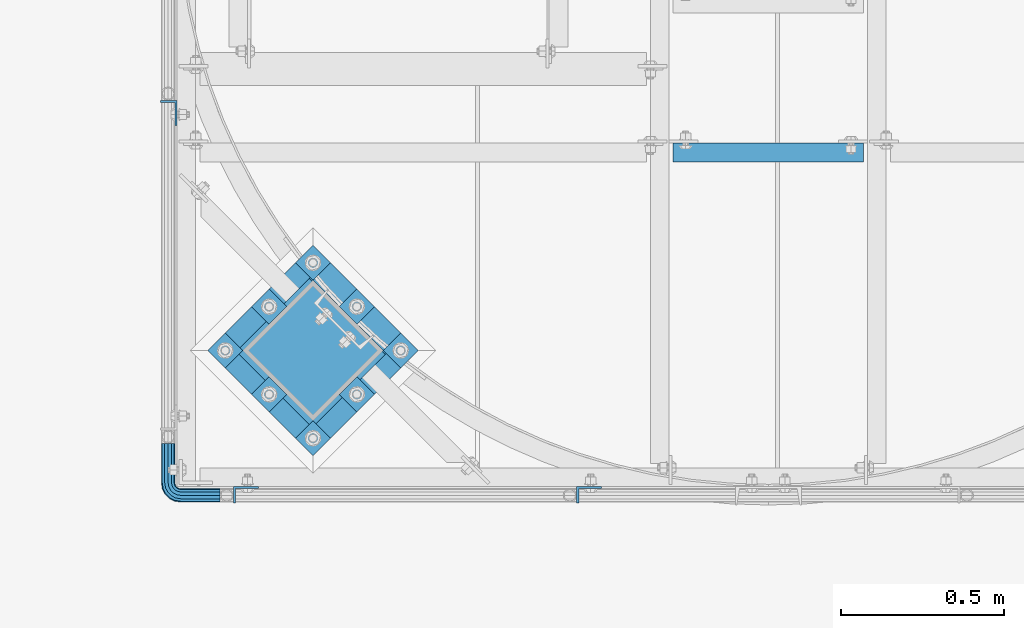
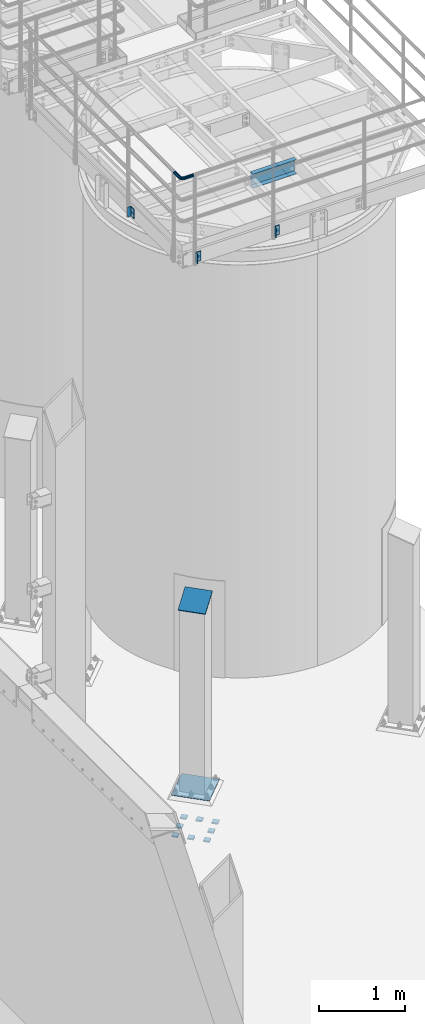
# One storey, part 1100 of 1876: 14 beams, 1 member, 5 elements without a shape of their own.
"""IFC2X3 building model written with IfcOpenShell, lengths in millimetres."""

from ifc_helpers import new_model, si_unit, frame, origin_with_axes, place, context, subcontext, project, spatial, faceted_brep, material, type_object, element, aggregate, save


model = new_model("IFC2X3")

# Units and contexts
model_context = context("Model", 3, precision=1e-05, world=origin_with_axes())
body_context = subcontext(model_context, "Body", "Model", "MODEL_VIEW")
ifc_project = project(units=[si_unit("LENGTHUNIT", "METRE", prefix="MILLI"), si_unit("AREAUNIT", "SQUARE_METRE"), si_unit("VOLUMEUNIT", "CUBIC_METRE"), si_unit("MASSUNIT", "GRAM", prefix="KILO"), si_unit("TIMEUNIT", "SECOND"), si_unit("PLANEANGLEUNIT", "RADIAN"), si_unit("SOLIDANGLEUNIT", "STERADIAN"), si_unit("THERMODYNAMICTEMPERATUREUNIT", "DEGREE_CELSIUS"), si_unit("LUMINOUSINTENSITYUNIT", "LUMEN")], contexts=[model_context])

# Site, building, storey
site_placement = place(None, origin_with_axes())
site = spatial("IfcSite", under=ifc_project, at=site_placement, CompositionType="ELEMENT")
building_placement = place(site_placement, origin_with_axes())
building = spatial("IfcBuilding", under=site, at=building_placement, Name="Undefined", CompositionType="ELEMENT")
storey_placement = place(building_placement, origin_with_axes())
storey = spatial("IfcBuildingStorey", under=building, at=storey_placement, Name="Undefined", CompositionType="ELEMENT", Elevation=0.0)

# Assembly, beam
assembly_1_placement = place(storey_placement, origin_with_axes())
assembly_1 = element("IfcElementAssembly", 1, at=assembly_1_placement, inside=storey, Name="HANDRAIL", AssemblyPlace="NOTDEFINED", PredefinedType="RIGID_FRAME")
ifc_material_1 = material()
beam_type_1 = type_object("IfcBeamType", Name="PIPE1-1/4STD", PredefinedType="NOTDEFINED")
beam_1_placement = place(assembly_1_placement, frame((3338.06943150122, -15273.6987792969, 9090.025), z_axis=(0.0, 0.0, -1.0), x_axis=(0.0, -1.0, 0.0)))
beam_1 = element("IfcBeam", 2, at=beam_1_placement, type_object=beam_type_1, material=ifc_material_1, Name="HANDRAIL", ObjectType="PIPE1-1/4STD", context=body_context, shape_type="Brep", body=[
    faceted_brep([(9.09494701772928e-13, -21.0820000000003, 0.0), (0.0, -18.2575475625836, -10.5409999999993), (120.697624206543, -18.2575475625817, -10.5410000000011), (120.697624206543, -21.0819999999985, -1.81898940354586e-12), (0.0, -10.5410000000002, -18.2575475625836), (120.697624206543, -10.5409999999983, -18.2575475625854), (-4.28826751885936e-09, 0.0, -21.0820000000003), (120.697624206542, 1.81898940354586e-12, -21.0820000000022), (0.0, 10.5410000000002, -18.2575475625836), (120.697624206542, 10.5410000000011, -18.2575475625854), (0.0, 18.2575475625836, -10.5409999999993), (120.697624206542, 18.2575475625845, -10.5410000000011), (9.09494701772928e-13, 21.0820000000003, 0.0), (120.697624206542, 21.0820000000012, -1.81898940354586e-12), (0.0, 18.2575475625836, 10.5409999999993), (120.697624206543, 18.2575475625845, 10.5409999999993), (0.0, 10.5410000000002, 18.2575475625836), (120.697624206543, 10.5410000000011, 18.2575475625817), (0.0, 0.0, 21.0820000000003), (120.697624206543, 1.81898940354586e-12, 21.0819999999985), (0.0, -10.5410000000002, 18.2575475625836), (120.697624206543, -10.5409999999983, 18.2575475625817), (0.0, -18.2575475625836, 10.5409999999993), (120.697624206543, -18.2575475625817, 10.5409999999993), (0.0, -17.5259999999998, 0.0), (0.0, -15.1779612267264, 8.76300000000083), (120.697624206543, -15.1779612267246, 8.76299999999901), (120.697624206543, -17.5259999999989, -1.81898940354586e-12), (0.0, -8.76299999999992, 15.1779612267255), (120.697624206543, -8.76299999999901, 15.1779612267255), (0.0, 0.0, 17.5259999999998), (120.697624206543, 1.81898940354586e-12, 17.525999999998), (0.0, 8.76299999999992, 15.1779612267255), (120.697624206543, 8.76300000000174, 15.1779612267255), (0.0, 15.1779612267264, 8.76300000000083), (120.697624206543, 15.1779612267273, 8.76299999999901), (0.0, 17.5259999999998, 0.0), (120.697624206542, 17.5260000000017, -1.81898940354586e-12), (0.0, 15.1779612267264, -8.76300000000083), (120.697624206542, 15.1779612267273, -8.76300000000083), (0.0, 8.76299999999992, -15.1779612267255), (120.697624206542, 8.76300000000174, -15.1779612267273), (0.0, 0.0, -17.5259999999998), (120.697624206542, 1.81898940354586e-12, -17.5260000000017), (0.0, -8.76299999999992, -15.1779612267255), (120.697624206543, -8.76299999999901, -15.1779612267273), (0.0, -15.1779612267264, -8.76300000000083), (120.697624206543, -15.1779612267246, -8.76300000000083), (125.956474945295, -21.9149201310065, -1.81898940354586e-12), (126.829278748261, -19.2287062354353, 10.5409999999993), (129.213823083002, -11.8898333927391, 18.2575475625817), (132.471171220709, -1.86474665447258, 21.0819999999985), (135.728519358417, 8.16034008379484, 18.2575475625817), (138.113063693158, 15.4992129264911, 10.5409999999993), (138.985867496124, 18.1854268220613, -1.81898940354586e-12), (138.113063693158, 15.4992129264911, -10.5410000000011), (135.728519358416, 8.16034008379393, -18.2575475625854), (132.471171220709, -1.86474665447258, -21.0820000000022), (129.213823083002, -11.8898333927391, -18.2575475625854), (126.829278748261, -19.2287062354353, -10.5410000000011), (137.887003064126, 14.803469850116, -1.81898940354586e-12), (137.161419179733, 12.5703522742797, 8.76299999999901), (135.179087142418, 6.46936159782126, 15.1779612267237), (132.471171220709, -1.86474665447258, 17.525999999998), (129.763255299001, -10.1988549067664, 15.1779612267255), (127.780923261686, -16.2998455832249, 8.76299999999901), (127.055339377293, -18.5329631590612, -1.81898940354586e-12), (127.780923261686, -16.2998455832249, -8.76300000000083), (129.763255299001, -10.1988549067664, -15.1779612267273), (132.471171220709, -1.86474665447258, -17.5260000000017), (135.179087142417, 6.46936159782126, -15.1779612267273), (137.161419179733, 12.5703522742797, -8.76300000000083), (149.288085766415, 1.2513959148082, 18.2575475625817), (153.823758622315, 7.49421403084034, 10.5409999999993), (143.092241421999, -7.27645222289721, 21.0819999999985), (136.896397077584, -15.8043003606035, 18.2575475625817), (132.360724221684, -22.0471184766357, 10.5409999999993), (130.700552733168, -24.3321484983098, -1.81898940354586e-12), (132.360724221683, -22.0471184766357, -10.5410000000011), (136.896397077584, -15.8043003606035, -18.2575475625854), (143.092241421999, -7.27645222289811, -21.0820000000022), (149.288085766414, 1.2513959148082, -18.2575475625854), (153.823758622315, 7.49421403084034, -10.5410000000011), (155.48393011083, 9.77924405251451, -1.81898940354586e-12), (152.013623190936, 5.00277634948725, -8.76300000000083), (153.393765753678, 6.90237962051742, -1.81898940354586e-12), (148.243003587838, -0.187036301190346, -15.1779612267273), (143.092241421999, -7.27645222289721, -17.5260000000017), (137.94147925616, -14.365868144605, -15.1779612267273), (134.170859653062, -19.5556807952826, -8.76300000000083), (132.79071709032, -21.4552840663118, -1.81898940354586e-12), (134.170859653062, -19.5556807952826, 8.76299999999901), (137.94147925616, -14.365868144605, 15.1779612267255), (143.092241421999, -7.27645222289721, 17.525999999998), (148.243003587839, -0.187036301190346, 15.1779612267237), (152.013623190936, 5.00277634948725, 8.76299999999901), (160.04901859547, -9.50953691424547, 18.2575475625817), (166.291836711502, -4.9738640583455, 10.5409999999993), (151.521170457764, -15.7053812586619, 21.0819999999985), (142.993322320059, -21.9012256030783, 18.2575475625817), (136.750504204027, -26.4368984589792, 10.5409999999993), (134.465474182353, -28.0970699474938, -1.81898940354586e-12), (136.750504204027, -26.4368984589792, -10.5410000000011), (142.993322320058, -21.9012256030783, -18.2575475625854), (151.521170457764, -15.7053812586619, -21.0820000000022), (160.04901859547, -9.50953691424638, -18.2575475625854), (166.291836711502, -4.9738640583455, -10.5410000000011), (168.576866733175, -3.31369256982998, -1.81898940354586e-12), (163.800399030148, -6.78399948972401, -8.76300000000083), (165.700002301178, -5.40385692698237, -1.81898940354586e-12), (158.610586379471, -10.5546190928226, -15.1779612267273), (151.521170457764, -15.7053812586619, -17.5260000000017), (144.431754536057, -20.8561434245021, -15.1779612267273), (139.24194188538, -24.6267630275997, -8.76300000000083), (137.34233861435, -26.0069055903414, -1.81898940354586e-12), (139.24194188538, -24.6267630275997, 8.76299999999901), (144.431754536057, -20.8561434245021, 15.1779612267255), (151.521170457764, -15.7053812586619, 17.525999999998), (158.610586379471, -10.5546190928217, 15.1779612267255), (163.800399030148, -6.78399948972401, 8.76299999999901), (166.957962764459, -23.0691033222502, 18.2575475625817), (174.296835607155, -20.6845589875093, 10.5409999999993), (156.932876026191, -26.3264514599568, 21.0819999999985), (146.907789287925, -29.5837995976626, 18.2575475625817), (139.568916445228, -31.9683439324035, 10.5409999999993), (136.882702549657, -32.8411477353693, -1.81898940354586e-12), (139.568916445228, -31.9683439324044, -10.5410000000011), (146.907789287924, -29.5837995976635, -18.2575475625854), (156.932876026191, -26.3264514599568, -21.0820000000022), (166.957962764458, -23.0691033222502, -18.2575475625854), (174.296835607155, -20.6845589875093, -10.5410000000011), (176.983049502726, -19.8117551845444, -1.81898940354586e-12), (171.367974954944, -21.6362035009342, -8.76300000000083), (173.60109253078, -20.9106196165412, -1.81898940354586e-12), (165.266984278486, -23.6185355382495, -15.1779612267273), (156.932876026191, -26.3264514599568, -17.5260000000017), (148.598767773897, -29.0343673816642, -15.1779612267273), (142.497777097438, -31.0166994189794, -8.76300000000083), (140.264659521603, -31.7422833033725, -1.81898940354586e-12), (142.497777097438, -31.0166994189794, 8.76299999999901), (148.598767773897, -29.0343673816642, 15.1779612267255), (156.932876026191, -26.3264514599568, 17.525999999998), (165.266984278486, -23.6185355382486, 15.1779612267255), (171.367974954945, -21.6362035009342, 8.76299999999901), (148.256622680664, -38.0999984741202, -18.2575475625854), (140.54007511808, -38.0999984741202, -10.5410000000011), (158.797622680664, -38.0999984741202, -21.0820000000003), (169.338622680664, -38.0999984741202, -18.2575475625854), (177.055170243248, -38.0999984741202, -10.5410000000011), (179.879622680664, -38.0999984741193, -1.81898940354586e-12), (177.055170243248, -38.0999984741193, 10.5409999999993), (169.338622680664, -38.0999984741193, 18.2575475625817), (158.797622680665, -38.0999984741193, 21.0819999999985), (148.256622680664, -38.0999984741193, 18.2575475625817), (140.540075118081, -38.0999984741193, 10.5409999999993), (137.715622680664, -38.0999984741193, -1.81898940354586e-12), (173.975583907391, -38.0999984741202, -8.76300000000083), (176.323622680664, -38.0999984741193, -1.81898940354586e-12), (167.560622680664, -38.0999984741202, -15.1779612267273), (158.797622680664, -38.0999984741202, -17.5260000000017), (150.034622680664, -38.0999984741202, -15.1779612267273), (143.619661453938, -38.0999984741202, -8.76300000000083), (141.271622680664, -38.0999984741193, -1.81898940354586e-12), (143.619661453938, -38.0999984741193, 8.76299999999901), (150.034622680665, -38.0999984741193, 15.1779612267255), (158.797622680665, -38.0999984741193, 17.525999999998), (167.560622680664, -38.0999984741193, 15.1779612267255), (173.975583907391, -38.0999984741193, 8.76299999999901), (140.54007511808, -158.750427246094, -10.5409999999993), (137.715622680664, -158.750427246094, 0.0), (148.256622680665, -158.750427246094, -18.2575475625836), (158.797622680664, -158.750427246094, -21.0820000000003), (169.338622680663, -158.750427246094, -18.2575475625836), (177.055170243248, -158.750427246094, -10.5409999999993), (179.879622680664, -158.750427246094, 0.0), (177.055170243248, -158.750427246094, 10.5409999999993), (169.338622680663, -158.750427246094, 18.2575475625836), (158.797622680664, -158.750427246094, 21.0820000000003), (148.256622680665, -158.750427246094, 18.2575475625836), (140.54007511808, -158.750427246094, 10.5409999999993), (143.619661453939, -158.750427246094, 8.76300000000083), (141.271622680664, -158.750427246094, 0.0), (150.034622680663, -158.750427246094, 15.1779612267255), (158.797622680664, -158.750427246094, 17.5259999999998), (167.560622680665, -158.750427246094, 15.1779612267255), (173.97558390739, -158.750427246094, 8.76300000000083), (176.323622680664, -158.750427246094, 0.0), (173.97558390739, -158.750427246094, -8.76300000000083), (167.560622680665, -158.750427246094, -15.1779612267255), (158.797622680664, -158.750427246094, -17.5259999999998), (150.034622680663, -158.750427246094, -15.1779612267255), (143.619661453939, -158.750427246094, -8.76300000000083)], [[[0, 1, 2, 3]], [[1, 4, 5, 2]], [[4, 6, 7, 5]], [[6, 8, 9, 7]], [[8, 10, 11, 9]], [[10, 12, 13, 11]], [[12, 14, 15, 13]], [[14, 16, 17, 15]], [[16, 18, 19, 17]], [[18, 20, 21, 19]], [[20, 22, 23, 21]], [[22, 0, 3, 23]], [[24, 25, 26, 27]], [[25, 28, 29, 26]], [[28, 30, 31, 29]], [[30, 32, 33, 31]], [[32, 34, 35, 33]], [[34, 36, 37, 35]], [[36, 38, 39, 37]], [[38, 40, 41, 39]], [[40, 42, 43, 41]], [[42, 44, 45, 43]], [[44, 46, 47, 45]], [[46, 24, 27, 47]], [[22, 20, 18, 16, 14, 12, 10, 8, 6, 4, 1, 0], [46, 44, 42, 40, 38, 36, 34, 32, 30, 28, 25, 24]], [[23, 3, 48, 49]], [[21, 23, 49, 50]], [[19, 21, 50, 51]], [[17, 19, 51, 52]], [[15, 17, 52, 53]], [[13, 15, 53, 54]], [[11, 13, 54, 55]], [[9, 11, 55, 56]], [[7, 9, 56, 57]], [[5, 7, 57, 58]], [[2, 5, 58, 59]], [[3, 2, 59, 48]], [[35, 37, 60, 61]], [[33, 35, 61, 62]], [[31, 33, 62, 63]], [[29, 31, 63, 64]], [[26, 29, 64, 65]], [[27, 26, 65, 66]], [[47, 27, 66, 67]], [[45, 47, 67, 68]], [[43, 45, 68, 69]], [[41, 43, 69, 70]], [[39, 41, 70, 71]], [[37, 39, 71, 60]], [[52, 72, 73, 53]], [[51, 74, 72, 52]], [[50, 75, 74, 51]], [[49, 76, 75, 50]], [[48, 77, 76, 49]], [[59, 78, 77, 48]], [[58, 79, 78, 59]], [[57, 80, 79, 58]], [[56, 81, 80, 57]], [[55, 82, 81, 56]], [[54, 83, 82, 55]], [[53, 73, 83, 54]], [[71, 84, 85, 60]], [[70, 86, 84, 71]], [[69, 87, 86, 70]], [[68, 88, 87, 69]], [[67, 89, 88, 68]], [[66, 90, 89, 67]], [[65, 91, 90, 66]], [[64, 92, 91, 65]], [[63, 93, 92, 64]], [[62, 94, 93, 63]], [[61, 95, 94, 62]], [[60, 85, 95, 61]], [[72, 96, 97, 73]], [[74, 98, 96, 72]], [[75, 99, 98, 74]], [[76, 100, 99, 75]], [[77, 101, 100, 76]], [[78, 102, 101, 77]], [[79, 103, 102, 78]], [[80, 104, 103, 79]], [[81, 105, 104, 80]], [[82, 106, 105, 81]], [[83, 107, 106, 82]], [[73, 97, 107, 83]], [[84, 108, 109, 85]], [[86, 110, 108, 84]], [[87, 111, 110, 86]], [[88, 112, 111, 87]], [[89, 113, 112, 88]], [[90, 114, 113, 89]], [[91, 115, 114, 90]], [[92, 116, 115, 91]], [[93, 117, 116, 92]], [[94, 118, 117, 93]], [[95, 119, 118, 94]], [[85, 109, 119, 95]], [[96, 120, 121, 97]], [[98, 122, 120, 96]], [[99, 123, 122, 98]], [[100, 124, 123, 99]], [[101, 125, 124, 100]], [[102, 126, 125, 101]], [[103, 127, 126, 102]], [[104, 128, 127, 103]], [[105, 129, 128, 104]], [[106, 130, 129, 105]], [[107, 131, 130, 106]], [[97, 121, 131, 107]], [[108, 132, 133, 109]], [[110, 134, 132, 108]], [[111, 135, 134, 110]], [[112, 136, 135, 111]], [[113, 137, 136, 112]], [[114, 138, 137, 113]], [[115, 139, 138, 114]], [[116, 140, 139, 115]], [[117, 141, 140, 116]], [[118, 142, 141, 117]], [[119, 143, 142, 118]], [[109, 133, 143, 119]], [[127, 144, 145, 126]], [[128, 146, 144, 127]], [[129, 147, 146, 128]], [[130, 148, 147, 129]], [[131, 149, 148, 130]], [[121, 150, 149, 131]], [[120, 151, 150, 121]], [[122, 152, 151, 120]], [[123, 153, 152, 122]], [[124, 154, 153, 123]], [[125, 155, 154, 124]], [[126, 145, 155, 125]], [[132, 156, 157, 133]], [[134, 158, 156, 132]], [[135, 159, 158, 134]], [[136, 160, 159, 135]], [[137, 161, 160, 136]], [[138, 162, 161, 137]], [[139, 163, 162, 138]], [[140, 164, 163, 139]], [[141, 165, 164, 140]], [[142, 166, 165, 141]], [[143, 167, 166, 142]], [[133, 157, 167, 143]], [[155, 145, 168, 169]], [[145, 144, 170, 168]], [[144, 146, 171, 170]], [[146, 147, 172, 171]], [[147, 148, 173, 172]], [[148, 149, 174, 173]], [[149, 150, 175, 174]], [[150, 151, 176, 175]], [[151, 152, 177, 176]], [[152, 153, 178, 177]], [[153, 154, 179, 178]], [[154, 155, 169, 179]], [[162, 163, 180, 181]], [[163, 164, 182, 180]], [[164, 165, 183, 182]], [[165, 166, 184, 183]], [[166, 167, 185, 184]], [[167, 157, 186, 185]], [[157, 156, 187, 186]], [[156, 158, 188, 187]], [[158, 159, 189, 188]], [[159, 160, 190, 189]], [[160, 161, 191, 190]], [[161, 162, 181, 191]], [[170, 171, 172, 173, 174, 175, 176, 177, 178, 179, 169, 168], [182, 183, 184, 185, 186, 187, 188, 189, 190, 191, 181, 180]]]),
])

assembly_2_placement = place(storey_placement, origin_with_axes())
assembly_2 = element("IfcElementAssembly", 3, at=assembly_2_placement, inside=storey, Name="HANDRAIL", AssemblyPlace="NOTDEFINED", PredefinedType="RIGID_FRAME")
ifc_material_2 = material(Name="STEEL/A36")
beam_type_2 = type_object("IfcBeamType", Name="L3X2X1/4", PredefinedType="NOTDEFINED")
beam_2_placement = place(assembly_2_placement, frame((3340.10143150122, -14257.7464042969, 7966.075), z_axis=(0.0, -1.0, 0.0), x_axis=(0.0, 0.0, -1.0)))
beam_2 = element("IfcBeam", 4, at=beam_2_placement, type_object=beam_type_2, material=ifc_material_2, Name="ANGLE", ObjectType="L3X2X1/4", context=body_context, shape_type="Brep", body=[
    faceted_brep([(0.0, 25.3999999999996, -38.1000000000004), (0.0, 25.3999999999996, 38.1000000000004), (139.7, 25.3999999999996, 38.1000000000004), (139.7, 25.3999999999996, -38.1000000000004), (0.0, 19.0500000000002, 38.1000000000004), (139.7, 19.0500000000002, 38.1000000000004), (0.0, 19.0500000000002, -31.75), (139.7, 19.0500000000002, -31.75), (0.0, -25.3999999999996, -31.75), (139.7, -25.3999999999996, -31.75), (0.0, -25.3999999999996, -38.1000000000004), (139.7, -25.3999999999996, -38.1000000000004)], [[[0, 1, 2, 3]], [[1, 4, 5, 2]], [[4, 6, 7, 5]], [[6, 8, 9, 7]], [[8, 10, 11, 9]], [[10, 0, 3, 11]], [[5, 7, 9, 11, 3, 2]], [[10, 8, 6, 4, 1, 0]]]),
])
aggregate(assembly_2, [beam_2])

# Beam
beam_3_placement = place(assembly_1_placement, frame((4631.18343150122, -15430.4644042969, 7966.075), z_axis=(1.0, 0.0, 0.0), x_axis=(0.0, 0.0, -1.0)))
beam_3 = element("IfcBeam", 5, at=beam_3_placement, type_object=beam_type_2, material=ifc_material_2, Name="ANGLE", ObjectType="L3X2X1/4", context=body_context, shape_type="Brep", body=[
    faceted_brep([(0.0, 25.3999999999996, -38.1000000000004), (0.0, 25.3999999999996, 38.1000000000004), (139.7, 25.3999999999996, 38.1000000000004), (139.7, 25.3999999999996, -38.1000000000004), (0.0, 19.0500000000002, 38.1000000000004), (139.7, 19.0500000000002, 38.1000000000004), (0.0, 19.0500000000002, -31.75), (139.7, 19.0500000000002, -31.75), (0.0, -25.3999999999996, -31.75), (139.7, -25.3999999999996, -31.75), (0.0, -25.3999999999996, -38.1000000000004), (139.7, -25.3999999999996, -38.1000000000004)], [[[0, 1, 2, 3]], [[1, 4, 5, 2]], [[4, 6, 7, 5]], [[6, 8, 9, 7]], [[8, 10, 11, 9]], [[10, 0, 3, 11]], [[5, 7, 9, 11, 3, 2]], [[10, 8, 6, 4, 1, 0]]]),
])

beam_4_placement = place(assembly_1_placement, frame((3577.08343150122, -15430.4644042969, 7966.075), z_axis=(1.0, 0.0, 0.0), x_axis=(0.0, 0.0, -1.0)))
beam_4 = element("IfcBeam", 6, at=beam_4_placement, type_object=beam_type_2, material=ifc_material_2, Name="ANGLE", ObjectType="L3X2X1/4", context=body_context, shape_type="Brep", body=[
    faceted_brep([(0.0, 25.3999999999996, -38.1000000000004), (0.0, 25.3999999999996, 38.1000000000004), (139.7, 25.3999999999996, 38.1000000000004), (139.7, 25.3999999999996, -38.1000000000004), (0.0, 19.0500000000002, 38.1000000000004), (139.7, 19.0500000000002, 38.1000000000004), (0.0, 19.0500000000002, -31.75), (139.7, 19.0500000000002, -31.75), (0.0, -25.3999999999996, -31.75), (139.7, -25.3999999999996, -31.75), (0.0, -25.3999999999996, -38.1000000000004), (139.7, -25.3999999999996, -38.1000000000004)], [[[0, 1, 2, 3]], [[1, 4, 5, 2]], [[4, 6, 7, 5]], [[6, 8, 9, 7]], [[8, 10, 11, 9]], [[10, 0, 3, 11]], [[5, 7, 9, 11, 3, 2]], [[10, 8, 6, 4, 1, 0]]]),
])

aggregate(assembly_1, [beam_1, beam_3, beam_4])

# Assembly, beam
assembly_3_placement = place(storey_placement, origin_with_axes())
assembly_3 = element("IfcElementAssembly", 7, at=assembly_3_placement, inside=storey, Name="BEAM", AssemblyPlace="NOTDEFINED", PredefinedType="RIGID_FRAME")
beam_type_3 = type_object("IfcBeamType", Name="C8X11.5", PredefinedType="NOTDEFINED")
beam_5_placement = place(assembly_3_placement, frame((4876.80143150122, -14379.5394042969, 7896.225), z_axis=(0.0, 0.0, 1.0), x_axis=(1.0, 0.0, 0.0)))
beam_5 = element("IfcBeam", 8, at=beam_5_placement, type_object=beam_type_3, material=ifc_material_2, Name="BEAM", ObjectType="C8X11.5", context=body_context, shape_type="Brep", body=[
    faceted_brep([(12.7000000000007, 28.5749999999998, -101.6), (12.7000000000007, 28.5749999999998, 101.6), (596.900000000001, 28.5750000000007, 101.6), (596.900000000001, 28.5750000000007, -101.6), (12.7000000000007, -28.5749999999998, 101.6), (596.900000000001, -28.5750000000007, 101.6), (12.7000000000007, -28.5749999999998, 96.8355949999996), (596.900000000001, -28.5750000000007, 96.8355949999996), (12.7000000000007, 22.2250000000004, 88.3723149999996), (596.900000000001, 22.2250000000004, 88.3723149999996), (12.7000000000007, 22.2250000000004, -88.3723149999996), (596.900000000001, 22.2250000000004, -88.3723149999996), (12.7000000000007, -28.5749999999998, -96.8355949999996), (596.900000000001, -28.5750000000007, -96.8355949999996), (12.7000000000007, -28.5749999999998, -101.6), (596.900000000001, -28.5750000000007, -101.6)], [[[0, 1, 2, 3]], [[1, 4, 5, 2]], [[4, 6, 7, 5]], [[6, 8, 9, 7]], [[8, 10, 11, 9]], [[10, 12, 13, 11]], [[12, 14, 15, 13]], [[14, 0, 3, 15]], [[5, 7, 9, 11, 13, 15, 3, 2]], [[14, 12, 10, 8, 6, 4, 1, 0]]]),
])
aggregate(assembly_3, [beam_5])

# Assembly, member
assembly_4_placement = place(storey_placement, origin_with_axes())
assembly_4 = element("IfcElementAssembly", 9, at=assembly_4_placement, inside=storey, Name="COLUMN", AssemblyPlace="NOTDEFINED", PredefinedType="RIGID_FRAME")
member_type = type_object("IfcMemberType", PredefinedType="NOTDEFINED")
member_placement = place(assembly_4_placement, frame((3889.14953329757, -14881.4504667301, 2749.16704824061), z_axis=(-0.707106781186548, 0.707106781186547, 0.0), x_axis=(-0.664463024761458, -0.664463024761456, -0.342020141877215)))
member = element("IfcMember", 10, at=member_placement, type_object=member_type, material=ifc_material_2, Name="PLATE", context=body_context, shape_type="Brep", body=[
    faceted_brep([(0.0, 6.35000000000042, -165.100000000026), (0.0, 6.35000000000042, 165.100000000029), (337.061384869998, 6.34999999999997, 165.099999999921), (337.061384869996, 6.34999999999997, -165.100000000135), (1.81898940354586e-12, -6.34999999999849, 165.100000000029), (337.061384869998, -6.3499999999994, 165.099999999921), (0.0, -6.34999999999894, -165.100000000026), (337.061384869998, -6.3499999999994, -165.100000000136)], [[[0, 1, 2, 3]], [[1, 4, 5, 2]], [[4, 6, 7, 5]], [[6, 0, 3, 7]], [[5, 7, 3, 2]], [[6, 4, 1, 0]]]),
])
aggregate(assembly_4, [member])

# Assembly, beams
assembly_5_placement = place(storey_placement, origin_with_axes())
assembly_5 = element("IfcElementAssembly", 11, at=assembly_5_placement, inside=storey, Name="TEMPLATE", AssemblyPlace="NOTDEFINED", PredefinedType="RIGID_FRAME")
beam_type_4 = type_object("IfcBeamType", PredefinedType="NOTDEFINED")
beam_6_placement = place(assembly_5_placement, frame((4079.27062606819, -14960.7370575648, -542.925), z_axis=(-0.707106781186548, 0.707106781186547, 0.0), x_axis=(-0.707106781186547, -0.707106781186548, 0.0)))
beam_6 = element("IfcBeam", 12, at=beam_6_placement, type_object=beam_type_4, material=ifc_material_2, Name="PLATE", context=body_context, shape_type="Brep", body=[
    faceted_brep([(0.0, 9.52499999999998, -38.1000000000058), (-9.09494701772928e-13, 9.52499999999998, 38.1000000000076), (76.2000000000762, 9.52499999999998, 38.1000000000058), (76.2000000000762, 9.52499999999998, -38.1000000000058), (-9.09494701772928e-13, -9.52499999999998, 38.1000000000076), (76.2000000000762, -9.52499999999998, 38.1000000000058), (0.0, -9.52499999999998, -38.1000000000058), (76.2000000000762, -9.52499999999998, -38.1000000000058)], [[[0, 1, 2, 3]], [[1, 4, 5, 2]], [[4, 6, 7, 5]], [[6, 0, 3, 7]], [[5, 7, 3, 2]], [[6, 4, 1, 0]]]),
])
beam_7_placement = place(assembly_5_placement, frame((3944.56678425195, -14826.0332157486, -542.925), z_axis=(-0.707106781186548, 0.707106781186547, 0.0), x_axis=(-0.707106781186547, -0.707106781186548, 0.0)))
beam_7 = element("IfcBeam", 13, at=beam_7_placement, type_object=beam_type_4, material=ifc_material_2, Name="PLATE", context=body_context, shape_type="Brep", body=[
    faceted_brep([(0.0, 9.52499999999998, -38.1000000000058), (-9.09494701772928e-13, 9.52499999999998, 38.1000000000076), (76.2000000000762, 9.52499999999998, 38.1000000000058), (76.2000000000762, 9.52499999999998, -38.1000000000058), (-9.09494701772928e-13, -9.52499999999998, 38.1000000000076), (76.2000000000762, -9.52499999999998, 38.1000000000058), (0.0, -9.52499999999998, -38.1000000000058), (76.2000000000762, -9.52499999999998, -38.1000000000058)], [[[0, 1, 2, 3]], [[1, 4, 5, 2]], [[4, 6, 7, 5]], [[6, 0, 3, 7]], [[5, 7, 3, 2]], [[6, 4, 1, 0]]]),
])
beam_8_placement = place(assembly_5_placement, frame((3809.86294243571, -14691.3293739324, -542.925), z_axis=(-0.707106781186548, 0.707106781186547, 0.0), x_axis=(-0.707106781186547, -0.707106781186548, 0.0)))
beam_8 = element("IfcBeam", 14, at=beam_8_placement, type_object=beam_type_4, material=ifc_material_2, Name="PLATE", context=body_context, shape_type="Brep", body=[
    faceted_brep([(0.0, 9.52499999999998, -38.1000000000058), (-9.09494701772928e-13, 9.52499999999998, 38.1000000000076), (76.2000000000762, 9.52499999999998, 38.1000000000058), (76.2000000000762, 9.52499999999998, -38.1000000000058), (-9.09494701772928e-13, -9.52499999999998, 38.1000000000076), (76.2000000000762, -9.52499999999998, 38.1000000000058), (0.0, -9.52499999999998, -38.1000000000058), (76.2000000000762, -9.52499999999998, -38.1000000000058)], [[[0, 1, 2, 3]], [[1, 4, 5, 2]], [[4, 6, 7, 5]], [[6, 0, 3, 7]], [[5, 7, 3, 2]], [[6, 4, 1, 0]]]),
])
beam_9_placement = place(assembly_5_placement, frame((3944.56678425195, -15095.4408993811, -542.925), z_axis=(-0.707106781186548, 0.707106781186547, 0.0), x_axis=(-0.707106781186547, -0.707106781186548, 0.0)))
beam_9 = element("IfcBeam", 15, at=beam_9_placement, type_object=beam_type_4, material=ifc_material_2, Name="PLATE", context=body_context, shape_type="Brep", body=[
    faceted_brep([(0.0, 9.52499999999998, -38.1000000000058), (-9.09494701772928e-13, 9.52499999999998, 38.1000000000076), (76.2000000000762, 9.52499999999998, 38.1000000000058), (76.2000000000762, 9.52499999999998, -38.1000000000058), (-9.09494701772928e-13, -9.52499999999998, 38.1000000000076), (76.2000000000762, -9.52499999999998, 38.1000000000058), (0.0, -9.52499999999998, -38.1000000000058), (76.2000000000762, -9.52499999999998, -38.1000000000058)], [[[0, 1, 2, 3]], [[1, 4, 5, 2]], [[4, 6, 7, 5]], [[6, 0, 3, 7]], [[5, 7, 3, 2]], [[6, 4, 1, 0]]]),
])
beam_10_placement = place(assembly_5_placement, frame((3675.15910061947, -14826.0332157486, -542.925), z_axis=(-0.707106781186548, 0.707106781186547, 0.0), x_axis=(-0.707106781186547, -0.707106781186548, 0.0)))
beam_10 = element("IfcBeam", 16, at=beam_10_placement, type_object=beam_type_4, material=ifc_material_2, Name="PLATE", context=body_context, shape_type="Brep", body=[
    faceted_brep([(0.0, 9.52499999999998, -38.1000000000058), (-9.09494701772928e-13, 9.52499999999998, 38.1000000000076), (76.2000000000762, 9.52499999999998, 38.1000000000058), (76.2000000000762, 9.52499999999998, -38.1000000000058), (-9.09494701772928e-13, -9.52499999999998, 38.1000000000076), (76.2000000000762, -9.52499999999998, 38.1000000000058), (0.0, -9.52499999999998, -38.1000000000058), (76.2000000000762, -9.52499999999998, -38.1000000000058)], [[[0, 1, 2, 3]], [[1, 4, 5, 2]], [[4, 6, 7, 5]], [[6, 0, 3, 7]], [[5, 7, 3, 2]], [[6, 4, 1, 0]]]),
])
beam_11_placement = place(assembly_5_placement, frame((3809.86294243571, -15230.1447411973, -542.925), z_axis=(-0.707106781186548, 0.707106781186547, 0.0), x_axis=(-0.707106781186547, -0.707106781186548, 0.0)))
beam_11 = element("IfcBeam", 17, at=beam_11_placement, type_object=beam_type_4, material=ifc_material_2, Name="PLATE", context=body_context, shape_type="Brep", body=[
    faceted_brep([(0.0, 9.52499999999998, -38.1000000000058), (-9.09494701772928e-13, 9.52499999999998, 38.1000000000076), (76.2000000000762, 9.52499999999998, 38.1000000000058), (76.2000000000762, 9.52499999999998, -38.1000000000058), (-9.09494701772928e-13, -9.52499999999998, 38.1000000000076), (76.2000000000762, -9.52499999999998, 38.1000000000058), (0.0, -9.52499999999998, -38.1000000000058), (76.2000000000762, -9.52499999999998, -38.1000000000058)], [[[0, 1, 2, 3]], [[1, 4, 5, 2]], [[4, 6, 7, 5]], [[6, 0, 3, 7]], [[5, 7, 3, 2]], [[6, 4, 1, 0]]]),
])
beam_12_placement = place(assembly_5_placement, frame((3675.15910061947, -15095.4408993811, -542.925), z_axis=(-0.707106781186548, 0.707106781186547, 0.0), x_axis=(-0.707106781186547, -0.707106781186548, 0.0)))
beam_12 = element("IfcBeam", 18, at=beam_12_placement, type_object=beam_type_4, material=ifc_material_2, Name="PLATE", context=body_context, shape_type="Brep", body=[
    faceted_brep([(0.0, 9.52499999999998, -38.1000000000058), (-9.09494701772928e-13, 9.52499999999998, 38.1000000000076), (76.2000000000762, 9.52499999999998, 38.1000000000058), (76.2000000000762, 9.52499999999998, -38.1000000000058), (-9.09494701772928e-13, -9.52499999999998, 38.1000000000076), (76.2000000000762, -9.52499999999998, 38.1000000000058), (0.0, -9.52499999999998, -38.1000000000058), (76.2000000000762, -9.52499999999998, -38.1000000000058)], [[[0, 1, 2, 3]], [[1, 4, 5, 2]], [[4, 6, 7, 5]], [[6, 0, 3, 7]], [[5, 7, 3, 2]], [[6, 4, 1, 0]]]),
])
beam_13_placement = place(assembly_5_placement, frame((3540.45525880322, -14960.7370575648, -542.925), z_axis=(-0.707106781186548, 0.707106781186547, 0.0), x_axis=(-0.707106781186547, -0.707106781186548, 0.0)))
beam_13 = element("IfcBeam", 19, at=beam_13_placement, type_object=beam_type_4, material=ifc_material_2, Name="PLATE", context=body_context, shape_type="Brep", body=[
    faceted_brep([(0.0, 9.52499999999998, -38.1000000000058), (-9.09494701772928e-13, 9.52499999999998, 38.1000000000076), (76.2000000000762, 9.52499999999998, 38.1000000000058), (76.2000000000762, 9.52499999999998, -38.1000000000058), (-9.09494701772928e-13, -9.52499999999998, 38.1000000000076), (76.2000000000762, -9.52499999999998, 38.1000000000058), (0.0, -9.52499999999998, -38.1000000000058), (76.2000000000762, -9.52499999999998, -38.1000000000058)], [[[0, 1, 2, 3]], [[1, 4, 5, 2]], [[4, 6, 7, 5]], [[6, 0, 3, 7]], [[5, 7, 3, 2]], [[6, 4, 1, 0]]]),
])
beam_type_5 = type_object("IfcBeamType", PredefinedType="NOTDEFINED")
beam_14_placement = place(assembly_5_placement, frame((3944.56678425165, -14826.0332157484, 40.4815), z_axis=(0.707106781186547, -0.707106781186548, 0.0), x_axis=(-0.707106781186547, -0.707106781186548, 0.0)))
beam_14 = element("IfcBeam", 20, at=beam_14_placement, type_object=beam_type_5, material=ifc_material_2, Name="TEMPLATE", context=body_context, shape_type="Brep", body=[
    faceted_brep([(9.09494701772928e-13, 2.3815, -228.600000000035), (-9.09494701772928e-13, 2.3815, 228.60000000004), (457.200000000363, 2.3815, 228.60000000004), (457.200000000362, 2.3815, -228.600000000037), (-9.09494701772928e-13, -2.3815, 228.60000000004), (457.200000000363, -2.3815, 228.60000000004), (9.09494701772928e-13, -2.3815, -228.600000000035), (457.200000000362, -2.3815, -228.600000000037)], [[[0, 1, 2, 3]], [[1, 4, 5, 2]], [[4, 6, 7, 5]], [[6, 0, 3, 7]], [[5, 7, 3, 2]], [[6, 4, 1, 0]]]),
])
aggregate(assembly_5, [beam_6, beam_7, beam_8, beam_9, beam_10, beam_11, beam_12, beam_13, beam_14])

save(model, "model.ifc")
